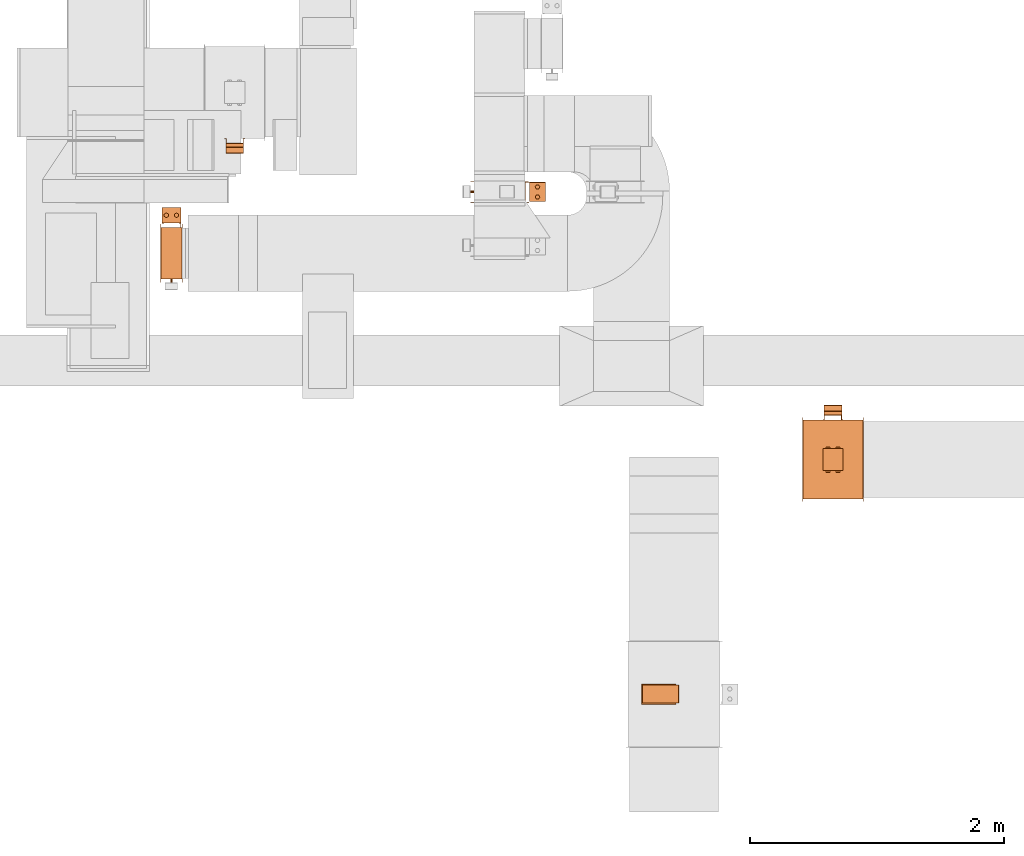
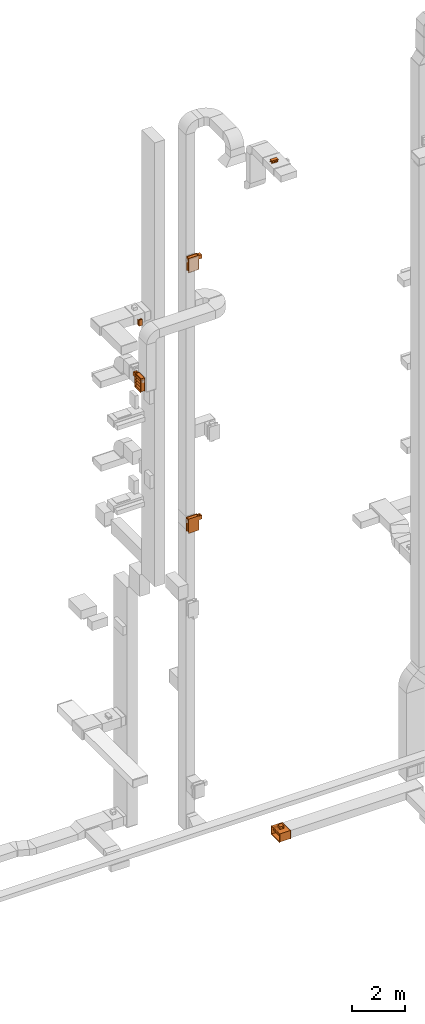
# One storey, part 25 of 29: 7 proxies.
"""IFC2X3 building model written with IfcOpenShell, lengths in millimetres."""

from ifc_helpers import new_model, entity, si_unit, converted_unit, derived_unit, direction, frame, frame_2d, origin, origin_2d_with_axis, place, context, subcontext, project, spatial, polyline, circle_curve, parameter, trimmed, segment, composite_curve, rectangle, circle, hollow_circle, outline, extrude, source, transform, mapped, material, material_list, type_object, type_shapes, element, save


model = new_model("IFC2X3")

# Units and contexts
model_context = context("Model", 3, precision=0.01, world=origin(), true_north=direction((6.12303176911189e-17, 1.0)))
body_context = subcontext(model_context, "Body", "Model", "MODEL_VIEW")
ifc_project = project(units=[si_unit("LENGTHUNIT", "METRE", prefix="MILLI"), si_unit("AREAUNIT", "SQUARE_METRE"), si_unit("VOLUMEUNIT", "CUBIC_METRE"), converted_unit("PLANEANGLEUNIT", "DEGREE", entity("IfcRatioMeasure", 0.0174532925199433), si_unit("PLANEANGLEUNIT", "RADIAN"), dimensions=[0, 0, 0, 0, 0, 0, 0]), si_unit("MASSUNIT", "GRAM", prefix="KILO"), derived_unit("MASSDENSITYUNIT", [(si_unit("MASSUNIT", "GRAM", prefix="KILO"), 1), (si_unit("LENGTHUNIT", "METRE"), -3)]), derived_unit("MOMENTOFINERTIAUNIT", [(si_unit("LENGTHUNIT", "METRE"), 4)]), si_unit("TIMEUNIT", "SECOND"), si_unit("FREQUENCYUNIT", "HERTZ"), si_unit("THERMODYNAMICTEMPERATUREUNIT", "DEGREE_CELSIUS"), derived_unit("THERMALTRANSMITTANCEUNIT", [(si_unit("MASSUNIT", "GRAM", prefix="KILO"), 1), (si_unit("THERMODYNAMICTEMPERATUREUNIT", "KELVIN"), -1), (si_unit("TIMEUNIT", "SECOND"), -3)]), derived_unit("VOLUMETRICFLOWRATEUNIT", [(si_unit("LENGTHUNIT", "METRE"), 3), (si_unit("TIMEUNIT", "SECOND"), -1)]), derived_unit("MASSFLOWRATEUNIT", [(si_unit("MASSUNIT", "GRAM", prefix="KILO"), 1), (si_unit("TIMEUNIT", "SECOND"), -1)]), derived_unit("ROTATIONALFREQUENCYUNIT", [(si_unit("TIMEUNIT", "SECOND"), -1)]), si_unit("ELECTRICCURRENTUNIT", "AMPERE"), si_unit("ELECTRICVOLTAGEUNIT", "VOLT"), si_unit("POWERUNIT", "WATT"), si_unit("FORCEUNIT", "NEWTON", prefix="KILO"), si_unit("ILLUMINANCEUNIT", "LUX"), si_unit("LUMINOUSFLUXUNIT", "LUMEN"), si_unit("LUMINOUSINTENSITYUNIT", "CANDELA"), derived_unit("USERDEFINED", [(si_unit("MASSUNIT", "GRAM", prefix="KILO"), -1), (si_unit("LENGTHUNIT", "METRE"), -2), (si_unit("TIMEUNIT", "SECOND"), 3), (si_unit("LUMINOUSFLUXUNIT", "LUMEN"), 1)]), derived_unit("LINEARVELOCITYUNIT", [(si_unit("LENGTHUNIT", "METRE"), 1), (si_unit("TIMEUNIT", "SECOND"), -1)]), si_unit("PRESSUREUNIT", "PASCAL"), derived_unit("USERDEFINED", [(si_unit("LENGTHUNIT", "METRE"), -2), (si_unit("MASSUNIT", "GRAM", prefix="KILO"), 1), (si_unit("TIMEUNIT", "SECOND"), -2)]), derived_unit("LINEARFORCEUNIT", [(si_unit("MASSUNIT", "GRAM", prefix="KILO"), 1), (si_unit("LENGTHUNIT", "METRE"), 1), (si_unit("TIMEUNIT", "SECOND"), -2), (si_unit("LENGTHUNIT", "METRE"), -1)]), derived_unit("PLANARFORCEUNIT", [(si_unit("MASSUNIT", "GRAM", prefix="KILO"), 1), (si_unit("LENGTHUNIT", "METRE"), 1), (si_unit("TIMEUNIT", "SECOND"), -2), (si_unit("LENGTHUNIT", "METRE"), -2)])], contexts=[model_context])

# Site, building, storey
site_placement = place(None, frame((0.0, -0.00077364408347762, 0.0)))
site = spatial("IfcSite", under=ifc_project, at=site_placement, CompositionType="ELEMENT")
building_placement = place(site_placement, origin())
building = spatial("IfcBuilding", under=site, at=building_placement, CompositionType="ELEMENT")
storey_placement = place(building_placement, origin())
storey = spatial("IfcBuildingStorey", under=building, at=storey_placement, CompositionType="ELEMENT", Elevation=0.0)

# Proxies
ifc_material_1 = material()
ifc_material_2 = material()
ifc_material_list_1 = material_list([ifc_material_1, ifc_material_2])
ifc_material_list_2 = material_list([ifc_material_1, ifc_material_1, ifc_material_2])
building_element_proxy_type_1 = type_object("IfcBuildingElementProxyType", PredefinedType="NOTDEFINED", material=ifc_material_list_2)
shared_shape_1 = source(origin(), body_context, "Body", "SweptSolid", [
    extrude(outline(composite_curve([segment(polyline([(-18.1579434264858, -147.53864987638), (18.0451391047457, -147.53864987638)]), True, "CONTINUOUS"), segment(trimmed(circle_curve(frame_2d((18.0451391047457, -139.094333839161), x_axis=(0.0, -1.0)), 8.44431603721898), [parameter(1.01777749806833e-13)], [parameter(90.0)], True, "PARAMETER"), True, "CONTINUOUS"), segment(polyline([(26.4894551419646, -139.094333839161), (26.4894551419649, 139.30552762976)]), True, "CONTINUOUS"), segment(trimmed(circle_curve(frame_2d((18.3336326481045, 139.30552762976), x_axis=(0.0, -1.0)), 8.15582249386043), [parameter(90.0)], [parameter(180.0)], True, "PARAMETER"), True, "CONTINUOUS"), segment(polyline([(18.3336326481046, 147.46135012362), (-18.1786488941653, 147.461350123621)]), True, "CONTINUOUS"), segment(trimmed(circle_curve(frame_2d((-18.1786488941652, 139.129454159721), x_axis=(0.0, -1.0)), 8.33189596389998), [parameter(180.0)], [parameter(270.0)], True, "PARAMETER"), True, "CONTINUOUS"), segment(polyline([(-26.5105448580647, 139.129454159721), (-26.5105448580641, -139.186048444801)]), True, "CONTINUOUS"), segment(trimmed(circle_curve(frame_2d((-18.1579434264858, -139.186048444801), x_axis=(0.0, -1.0)), 8.35260143157827), [parameter(270.0)], [parameter(4.57999874130747e-13)], True, "PARAMETER"), True, "CONTINUOUS")], self_intersect=False)), frame((-70.0, 12.5386498763715, 91.489455141968), z_axis=(1.0, 0.0, 0.0), x_axis=(0.0, 0.0, -1.0)), (0.0, 0.0, 1.0), 139.999999999992),
    extrude(outline(polyline([(-9.1666666666746, -80.0), (-4.16666666666706, -80.0), (-4.16666666667189, -70.0), (15.8333333333402, -70.0), (15.8333333333402, 70.0), (-4.16666666666706, 70.0), (-4.16666666666706, 80.0), (-9.16666666667441, 80.0), (-9.16666666667492, 65.0), (10.8333333333455, 65.0), (10.8333333333455, -65.0), (-9.16666666667441, -65.0), (-9.1666666666746, -80.0)])), frame((-70.0, 0.0, 49.1666666666727), z_axis=(1.0, 0.0, 0.0), x_axis=(0.0, 0.0, 1.0)), (0.0, 0.0, 1.0), 139.999999999992),
    extrude(outline(polyline([(-14.1666666666698, -80.0), (-9.16666666666213, -80.0), (-9.16666666666697, -70.0), (25.833333333333, -70.0), (25.833333333333, 70.0), (-9.16666666666213, 70.0), (-9.16666666666211, 80.0), (-14.1666666666695, 80.0), (-14.16666666667, 65.0), (20.833333333333, 65.0), (20.833333333333, -65.0), (-14.1666666666695, -65.0), (-14.1666666666698, -80.0)])), frame((0.0, -135.0, 14.1666666666679), z_axis=(0.0, 1.0, 0.0), x_axis=(0.0, 0.0, 1.0)), (0.0, 0.0, 1.0), 270.0),
])
type_shapes(building_element_proxy_type_1, [shared_shape_1])
proxy_1_placement = place(storey_placement, frame((29783.9052184742, 10927.6152449867, 22380.0), z_axis=(0.0, -1.0, 0.0), x_axis=(1.0, 0.0, 0.0)))
element("IfcBuildingElementProxy", 1, at=proxy_1_placement, inside=storey, type_object=building_element_proxy_type_1, material=ifc_material_list_1, context=body_context, shape_type="MappedRepresentation", body=[
    mapped(shared_shape_1, transform((0.0, 0.0, 0.0), scale=1.0)),
])
ifc_material_list_3 = material_list([ifc_material_1, ifc_material_2])
proxy_2_placement = place(storey_placement, frame((33124.0200965316, 6552.95842798016, 31212.0), z_axis=(0.0, 0.0, 1.0), x_axis=(0.0, -1.0, 0.0)))
element("IfcBuildingElementProxy", 2, at=proxy_2_placement, inside=storey, type_object=building_element_proxy_type_1, material=ifc_material_list_3, context=body_context, shape_type="MappedRepresentation", body=[
    mapped(shared_shape_1, transform((0.0, 0.0, 0.0), scale=1.0)),
])
ifc_material_list_4 = material_list([ifc_material_1, ifc_material_2])
proxy_3_placement = place(storey_placement, frame((34495.3986486254, 8712.00003916104, -1370.0), z_axis=(0.0, 1.0, 0.0), x_axis=(-1.0, 0.0, 0.0)))
element("IfcBuildingElementProxy", 3, at=proxy_3_placement, inside=storey, type_object=building_element_proxy_type_1, material=ifc_material_list_4, context=body_context, shape_type="MappedRepresentation", body=[
    mapped(shared_shape_1, transform((0.0, 0.0, 0.0), scale=1.0)),
])
ifc_material_3 = material()
ifc_material_4 = material()
ifc_material_5 = material()
ifc_material_list_5 = material_list([ifc_material_3, ifc_material_4, ifc_material_5, ifc_material_2])
ifc_material_list_6 = material_list([ifc_material_3, ifc_material_3, ifc_material_3, ifc_material_3, ifc_material_3, ifc_material_3, ifc_material_3, ifc_material_3, ifc_material_3, ifc_material_3, ifc_material_3, ifc_material_3, ifc_material_3, ifc_material_3, ifc_material_4, ifc_material_5, ifc_material_2, ifc_material_2, ifc_material_2, ifc_material_2, ifc_material_2, ifc_material_2, ifc_material_2, ifc_material_2, ifc_material_2, ifc_material_2])
building_element_proxy_type_2 = type_object("IfcBuildingElementProxyType", PredefinedType="NOTDEFINED", material=ifc_material_list_6)
shared_shape_2 = source(origin(), body_context, "Body", "SweptSolid", [
    extrude(rectangle(XDim=1.50000000000003, YDim=150.0, at=frame_2d((0.0, 7.105427357601e-15), x_axis=(1.0, 0.0))), frame((0.0, 202.250000000103, 157.249999999651), z_axis=(0.0, 0.0, 1.0), x_axis=(0.0, -1.0, 0.0)), (0.0, 0.0, 1.0), 123.000000000001),
    extrude(outline(polyline([(-11.6740264080913, -10.5031464839717), (-10.1740264080919, -10.5031464839717), (-10.1740264080919, 4.49685351602811), (21.8480528161833, 4.49685351602811), (21.8480528161832, 6.00629296794362), (-11.6740264080913, 6.00629296794362), (-11.6740264080913, -10.5031464839717)])), frame((68.9937070320596, 224.825973592012, 157.249999999651), z_axis=(0.0, 0.0, 1.0), x_axis=(0.0, -1.0, 0.0)), (0.0, 0.0, 1.0), 25.0),
    extrude(outline(polyline([(-10.5031464839719, -11.6740264080911), (6.00629296794368, -11.6740264080911), (6.00629296794368, 21.8480528161829), (4.4968535160282, 21.8480528161829), (4.49685351602819, -10.1740264080918), (-10.5031464839718, -10.1740264080917), (-10.5031464839719, -11.6740264080911)])), frame((-68.9937070320598, 224.825973592013, 157.24999999965), z_axis=(0.0, 0.0, 1.0), x_axis=(-1.0, 0.0, 0.0)), (0.0, 0.0, 1.0), 25.0000000000005),
    extrude(outline(polyline([(-11.6740264080912, -10.503146483972), (-10.1740264080917, -10.503146483972), (-10.174026408092, 4.49685351602798), (21.8480528161832, 4.49685351602851), (21.8480528161831, 6.00629296794398), (-11.6740264080914, 6.00629296794359), (-11.6740264080912, -10.503146483972)])), frame((68.9937070320592, 224.825973592012, 255.249999999653), z_axis=(0.0, 0.0, 1.0), x_axis=(0.0, -1.0, 0.0)), (0.0, 0.0, 1.0), 25.0),
    extrude(outline(polyline([(-9.31403727272934, -16.1323857799607), (9.31403727274035, -16.1323857799607), (18.6280745454669, 0.0), (9.31403727272391, 16.132385779964), (-9.31403727273757, 16.1323857799592), (-18.6280745454642, 0.0), (-9.31403727272934, -16.1323857799607)])), frame((40.0, 299.0, 307.249999999651), z_axis=(0.0, 0.0, 1.0), x_axis=(0.866025403784569, 0.499999999999775, 0.0)), (0.0, 0.0, 1.0), 10.0),
    extrude(outline(polyline([(-9.25778653448417, -16.0349566433469), (9.25778653447845, -16.0349566433469), (18.5155730689596, 0.0), (9.25778653447818, 16.0349566433504), (-9.25778653447542, 16.0349566433453), (-18.5155730689565, 0.0), (-9.25778653448417, -16.0349566433469)])), frame((-40.0, 299.0, 307.249999999651), z_axis=(0.0, 0.0, 1.0), x_axis=(0.866025403784445, 0.499999999999988, 0.0)), (0.0, 0.0, 1.0), 10.0),
    extrude(hollow_circle(Radius=15.0, WallThickness=6.97527274236894, at=frame_2d((1.09711940467341e-28, -6.76791955811495e-14), x_axis=(1.0, 0.0))), frame((-40.0, 299.0, 305.249999999651), z_axis=(0.0, 0.0, 1.0), x_axis=(-1.0, 0.0, 0.0)), (0.0, 0.0, 1.0), 14.0),
    extrude(hollow_circle(Radius=15.0, WallThickness=7.0, at=frame_2d((1.09711940467341e-28, -6.76791955811495e-14), x_axis=(1.0, 0.0))), frame((40.0, 299.0, 305.249999999651), z_axis=(0.0, 0.0, 1.0), x_axis=(-1.0, 0.0, 0.0)), (0.0, 0.0, 1.0), 14.0),
    extrude(outline(polyline([(-10.5031464839719, -11.6740264080911), (6.00629296794375, -11.6740264080911), (6.00629296794375, 21.848052816183), (4.49685351602825, 21.848052816183), (4.49685351602798, -10.1740264080918), (-10.5031464839719, -10.1740264080917), (-10.5031464839719, -11.6740264080911)])), frame((-68.9937070320603, 224.825973592013, 255.249999999653), z_axis=(0.0, 0.0, 1.0), x_axis=(-1.0, 0.0, 0.0)), (0.0, 0.0, 1.0), 25.0),
    extrude(outline(polyline([(-9.31403727272938, -16.1323857799607), (9.31403727274159, -16.1323857799607), (18.6280745454675, 0.0), (9.31403727272273, 16.1323857799646), (-9.31403727273821, 16.1323857799588), (-18.6280745454642, 0.0), (-9.31403727272938, -16.1323857799607)])), frame((40.0, 299.0, 120.249999999651), z_axis=(0.0, 0.0, 1.0), x_axis=(0.866025403784588, 0.499999999999741, 0.0)), (0.0, 0.0, 1.0), 9.99999999999999),
    extrude(outline(polyline([(-9.25778653448427, -16.0349566433469), (9.25778653447836, -16.0349566433469), (18.5155730689595, 0.0), (9.25778653447752, 16.0349566433508), (-9.25778653447492, 16.034956643345), (-18.5155730689561, 0.0), (-9.25778653448427, -16.0349566433469)])), frame((-40.0, 299.0, 120.249999999651), z_axis=(0.0, 0.0, 1.0), x_axis=(0.866025403784446, 0.499999999999988, 0.0)), (0.0, 0.0, 1.0), 9.99999999999999),
    extrude(hollow_circle(Radius=15.0, WallThickness=6.97527274236894, at=frame_2d((1.09711940467341e-28, -6.76791955811495e-14), x_axis=(1.0, 0.0))), frame((-40.0, 299.0, 118.249999999651), z_axis=(0.0, 0.0, 1.0), x_axis=(-1.0, 0.0, 0.0)), (0.0, 0.0, 1.0), 14.0000000000001),
    extrude(hollow_circle(Radius=15.0, WallThickness=7.0, at=frame_2d((1.09711940467341e-28, -6.76791955811495e-14), x_axis=(1.0, 0.0))), frame((40.0, 299.0, 118.249999999651), z_axis=(0.0, 0.0, 1.0), x_axis=(-1.0, 0.0, 0.0)), (0.0, 0.0, 1.0), 14.0000000000001),
    extrude(rectangle(XDim=125.0, YDim=150.0, at=frame_2d((3.19744231092045e-14, 7.105427357601e-15), x_axis=(1.0, 0.0))), frame((0.0, 299.0, 132.24999999965), z_axis=(0.0, 0.0, 1.0), x_axis=(0.0, -1.0, 0.0)), (0.0, 0.0, 1.0), 173.0),
    extrude(outline(polyline([(-91.9238815542516, -374.76659402887), (-49.4974746830587, -374.76659402887), (374.76659402887, 49.4974746830578), (374.76659402887, 91.9238815542507), (91.9238815542516, 374.76659402887), (49.4974746830586, 374.76659402887), (-374.76659402887, -49.4974746830577), (-374.76659402887, -91.9238815542507), (-91.9238815542516, -374.76659402887)]), holes=[polyline([(-70.7106781186565, -353.553390593272), (-353.553390593276, -70.7106781186521), (70.7106781186561, 353.553390593279), (353.553390593276, 70.7106781186588), (-70.7106781186565, -353.553390593272)])]), frame((85.0, 0.0, 0.0), z_axis=(1.0, 0.0, 0.0), x_axis=(0.0, -0.707106781186547, -0.707106781186548)), (0.0, 0.0, 1.0), 1.50000000000001),
    extrude(rectangle(XDim=1.5, YDim=400.0, at=frame_2d((-8.43769498715119e-15, 0.0), x_axis=(1.0, 0.0))), frame((85.7499999999981, 0.0, -300.0)), (0.0, 0.0, 1.0), 600.0),
    extrude(outline(polyline([(-10.7590541572762, -14.9949864557884), (14.2409458427174, -14.9949864557884), (69.8296772996113, -6.991007520203), (69.8296772996113, 6.98098043177924), (14.2409458427207, 15.0050135442119), (-10.7590541572817, 15.005013544212), (-73.3115689850514, 6.98098043177936), (-73.3115689850514, -6.99100752020272), (-10.7590541572762, -14.9949864557884)])), frame((-1.19744613134584, -201.500000000081, 70.9214102133944), z_axis=(0.0, 1.0, 0.0), x_axis=(0.707106781186548, 0.0, 0.707106781186548)), (0.0, 0.0, 1.0), 400.0),
    extrude(outline(polyline([(-10.7590541572762, -14.9949864557884), (14.2409458427174, -14.9949864557884), (69.8296772996113, -6.991007520203), (69.8296772996113, 6.98098043177924), (14.2409458427207, 15.0050135442119), (-10.7590541572817, 15.005013544212), (-73.3115689850514, 6.98098043177937), (-73.3115689850514, -6.99100752020272), (-10.7590541572762, -14.9949864557884)])), frame((-1.19744613134584, -201.50000000008, -73.9119231199388), z_axis=(0.0, 1.0, 0.0), x_axis=(0.707106781186548, 0.0, 0.707106781186548)), (0.0, 0.0, 1.0), 400.0),
    extrude(outline(polyline([(-10.7590541572762, -14.9949864557884), (14.2409458427174, -14.9949864557884), (69.8296772996113, -6.99100752020298), (69.8296772996113, 6.98098043177923), (14.2409458427207, 15.0050135442119), (-10.7590541572817, 15.005013544212), (-73.3115689850514, 6.98098043177935), (-73.3115689850514, -6.99100752020274), (-10.7590541572762, -14.9949864557884)])), frame((-1.19744613134584, -201.50000000008, 215.754743546728), z_axis=(0.0, 1.0, 0.0), x_axis=(0.707106781186548, 0.0, 0.707106781186548)), (0.0, 0.0, 1.0), 400.0),
    extrude(outline(polyline([(-10.7590541572762, -14.9949864557884), (14.2409458427174, -14.9949864557884), (69.8296772996113, -6.99100752020298), (69.8296772996113, 6.98098043177923), (14.2409458427207, 15.0050135442119), (-10.7590541572817, 15.005013544212), (-73.3115689850514, 6.98098043177935), (-73.3115689850514, -6.99100752020274), (-10.7590541572762, -14.9949864557884)])), frame((-1.19744613134584, -201.500000000081, -218.745256453272), z_axis=(0.0, 1.0, 0.0), x_axis=(0.707106781186548, 0.0, 0.707106781186548)), (0.0, 0.0, 1.0), 400.0),
    extrude(outline(polyline([(-201.500000000085, -301.500000000003), (201.500000000085, -301.500000000003), (201.500000000085, 301.500000000003), (-201.500000000085, 301.500000000003), (-201.500000000085, -301.500000000003)]), holes=[polyline([(200.0, -300.0), (-200.0, -300.0), (-200.0, 300.0), (200.0, 300.0), (200.0, -300.0)])]), frame((-83.5000000000015, 0.0, 0.0), z_axis=(1.0, 0.0, 0.0), x_axis=(0.0, -1.0, 0.0)), (0.0, 0.0, 1.0), 167.0),
    extrude(rectangle(XDim=1.5, YDim=400.000000000054, at=origin_2d_with_axis()), frame((-0.75, 0.0, 291.0), z_axis=(0.0, 0.0, 1.0), x_axis=(-1.0, 0.0, 0.0)), (0.0, 0.0, 1.0), 8.99999999964964),
    extrude(rectangle(XDim=1.5, YDim=399.999999999998, at=origin_2d_with_axis()), frame((-0.75, 0.0, -300.0), z_axis=(0.0, 0.0, 1.0), x_axis=(-1.0, 0.0, 0.0)), (0.0, 0.0, 1.0), 9.00000000035571),
    extrude(outline(polyline([(-330.0, -229.983568238304), (-301.500000000001, -229.983568238304), (301.499999999999, -229.983568238304), (330.0, -229.983568238304), (330.0, 229.983568238304), (301.499999999999, 229.983568238304), (-301.500000000001, 229.983568238304), (-330.0, 229.983568238304), (-330.0, -229.983568238304)]), holes=[polyline([(-300.0, 200.016431761674), (300.0, 200.016431761674), (300.0, -199.983568238324), (-300.0, -199.983568238324), (-300.0, 200.016431761674)])]), frame((83.4999999999988, -0.0164317617789846, 0.0), z_axis=(1.0, 0.0, 0.0), x_axis=(0.0, 0.0, -1.0)), (0.0, 0.0, 1.0), 1.49999999999925),
    extrude(outline(polyline([(-330.0, -229.983568238491), (-301.5, -229.983568238491), (301.5, -229.983568238491), (330.0, -229.983568238491), (330.0, 229.983568238491), (301.5, 229.983568238491), (-301.5, 229.983568238492), (-330.0, 229.983568238491), (-330.0, -229.983568238491)]), holes=[polyline([(-300.0, 200.016431761505), (300.0, 200.016431761505), (300.0, -199.983568238493), (-300.0, -199.983568238493), (-300.0, 200.016431761505)])]), frame((-85.0, -0.0164317615959716, 0.0), z_axis=(1.0, 0.0, 0.0), x_axis=(0.0, 0.0, -1.0)), (0.0, 0.0, 1.0), 1.50000000000074),
    extrude(circle(Radius=8.0, at=frame_2d((0.0, -1.29243565954607e-14), x_axis=(1.0, 0.0))), frame((0.0, -230.0, 218.750000000002), z_axis=(0.0, 1.0, 0.0), x_axis=(0.0, 0.0, 1.0)), (0.0, 0.0, 1.0), 28.5),
])
type_shapes(building_element_proxy_type_2, [shared_shape_2])
proxy_4_placement = place(storey_placement, frame((31869.8913763301, 10507.4235279463, 24600.0), z_axis=(0.0, 0.0, 1.0), x_axis=(0.0, -1.0, 0.0)))
element("IfcBuildingElementProxy", 4, at=proxy_4_placement, inside=storey, type_object=building_element_proxy_type_2, material=ifc_material_list_5, context=body_context, shape_type="MappedRepresentation", body=[
    mapped(shared_shape_2, transform((0.0, 0.0, 0.0), scale=1.0)),
])
ifc_material_list_7 = material_list([ifc_material_3, ifc_material_4, ifc_material_5, ifc_material_2])
proxy_5_placement = place(storey_placement, frame((29285.5638771014, 10024.9425362384, 20300.0)))
element("IfcBuildingElementProxy", 5, at=proxy_5_placement, inside=storey, type_object=building_element_proxy_type_2, material=ifc_material_list_7, context=body_context, shape_type="MappedRepresentation", body=[
    mapped(shared_shape_2, transform((0.0, 0.0, 0.0), scale=1.0)),
])
ifc_material_list_8 = material_list([ifc_material_3, ifc_material_4, ifc_material_5, ifc_material_2])
proxy_6_placement = place(storey_placement, frame((31869.8913763301, 10509.9993759155, 12600.0), z_axis=(0.0, 0.0, 1.0), x_axis=(0.0, -1.0, 0.0)))
element("IfcBuildingElementProxy", 6, at=proxy_6_placement, inside=storey, type_object=building_element_proxy_type_2, material=ifc_material_list_8, context=body_context, shape_type="MappedRepresentation", body=[
    mapped(shared_shape_2, transform((0.0, 0.0, 0.0), scale=1.0)),
])
ifc_material_list_9 = material_list([ifc_material_3, ifc_material_3, ifc_material_3, ifc_material_3, ifc_material_3, ifc_material_3, ifc_material_3, ifc_material_3, ifc_material_3, ifc_material_3, ifc_material_3, ifc_material_3, ifc_material_3, ifc_material_3, ifc_material_2, ifc_material_2, ifc_material_2, ifc_material_2, ifc_material_2])
ifc_material_list_10 = material_list([ifc_material_3, ifc_material_3, ifc_material_3, ifc_material_3, ifc_material_3, ifc_material_3, ifc_material_3, ifc_material_3, ifc_material_3, ifc_material_3, ifc_material_3, ifc_material_3, ifc_material_3, ifc_material_3, ifc_material_2, ifc_material_2, ifc_material_2, ifc_material_2, ifc_material_2])
building_element_proxy_type_3 = type_object("IfcBuildingElementProxyType", PredefinedType="NOTDEFINED", material=ifc_material_list_10)
shared_shape_3 = source(origin(), body_context, "Body", "SweptSolid", [
    extrude(rectangle(XDim=1.5, YDim=170.0, at=origin_2d_with_axis()), frame((0.0, -187.750000000076, -62.0), z_axis=(0.0, 0.0, 1.0), x_axis=(0.0, 1.0, 0.0)), (0.0, 0.0, 1.0), 123.000000000001),
    extrude(outline(polyline([(-5.0073597414186, -14.1635201826924), (-3.50735974141924, -14.1635201826924), (-3.50735974141928, 6.32704036539947), (8.51471948283784, 6.3270403654089), (8.51471948283784, 7.83647981728816), (-5.0073597414186, 7.83647981728816), (-5.0073597414186, -14.1635201826924)])), frame((-72.1635201826895, -196.99264025864, -62.0), z_axis=(0.0, 0.0, 1.0), x_axis=(0.0, 1.0, 0.0)), (0.0, 0.0, 1.0), 25.0),
    extrude(outline(polyline([(-13.8364798173165, -5.00735974141877), (7.67295963462824, -5.00735974141877), (7.67295963462824, 8.51471948283771), (6.16352018269341, 8.51471948283771), (6.16352018268311, -3.50735974141894), (-13.8364798173165, -3.50735974141894), (-13.8364798173165, -5.00735974141877)])), frame((72.3270403653872, -196.99264025864, -62.0)), (0.0, 0.0, 1.0), 25.0000000000005),
    extrude(outline(polyline([(-5.0073597414185, -14.163520182702), (-3.50735974141951, -14.163520182702), (-3.50735974141951, 6.3270403653898), (8.51471948283794, 6.32704036538944), (8.51471948283794, 7.83647981731237), (-5.0073597414185, 7.83647981731237), (-5.0073597414185, -14.163520182702)])), frame((-72.1635201826969, -196.99264025864, 36.0), z_axis=(0.0, 0.0, 1.0), x_axis=(0.0, 1.0, 0.0)), (0.0, 0.0, 1.0), 25.0),
    extrude(outline(polyline([(-9.39005042212512, -16.0890911238458), (8.81483867126942, -16.0890911238458), (18.3453872917851, -0.0836606621788718), (9.67104681890712, 15.9217697994894), (-8.95533686966041, 16.172751786024), (-18.4858854901761, 0.167321324356962), (-9.39005042212512, -16.0890911238458)])), frame((-39.8364798173101, -264.500000000062, 88.0), z_axis=(0.0, 0.0, 1.0), x_axis=(-0.859210135894937, -0.511622851693906, 0.0)), (0.0, 0.0, 1.0), 9.99999999999999),
    extrude(outline(polyline([(-9.25778653449055, -16.0349566433433), (9.25778653447246, -16.0349566433433), (18.5155730689534, 0.0), (9.25778653447181, 16.0349566433542), (-9.25778653446301, 16.0349566433379), (-18.515573068944, 0.0), (-9.25778653449055, -16.0349566433433)])), frame((40.0, -264.500000000057, 88.0), z_axis=(0.0, 0.0, 1.0), x_axis=(-0.86602540378445, -0.499999999999979, 0.0)), (0.0, 0.0, 1.0), 10.0),
    extrude(hollow_circle(Radius=15.0, WallThickness=6.97527274236894, at=frame_2d((3.55257043274876e-28, -6.76791955811494e-14), x_axis=(1.0, 0.0))), frame((40.0, -264.500000000057, 86.0)), (0.0, 0.0, 1.0), 14.0),
    extrude(hollow_circle(Radius=15.0, WallThickness=7.0, at=frame_2d((1.00544105397778e-41, -6.76791955811495e-14), x_axis=(1.0, 0.0))), frame((-40.0, -264.500000000057, 86.0)), (0.0, 0.0, 1.0), 14.0),
    extrude(outline(polyline([(-13.8364798173041, -5.0073597414186), (7.67295963460837, -5.0073597414186), (7.67295963460837, 8.51471948283787), (6.16352018269594, 8.51471948283787), (6.1635201826955, -3.50735974141934), (-13.8364798173041, -3.50735974141934), (-13.8364798173041, -5.0073597414186)])), frame((72.3270403653869, -196.99264025864, 36.0)), (0.0, 0.0, 1.0), 25.0),
    extrude(outline(polyline([(-9.39005042212341, -16.0890911238458), (8.81483867127266, -16.0890911238458), (18.3453872917859, -0.0836606621775066), (9.67104681890322, 15.9217697994909), (-8.95533686966253, 16.1727517860234), (-18.4858854901759, 0.167321324354935), (-9.39005042212341, -16.0890911238458)])), frame((-39.8364798173151, -264.500000000064, -98.0), z_axis=(0.0, 0.0, 1.0), x_axis=(-0.859210135895012, -0.511622851693779, 0.0)), (0.0, 0.0, 1.0), 9.99999999999999),
    extrude(outline(polyline([(-9.25778653449123, -16.0349566433429), (9.2577865344714, -16.0349566433429), (18.5155730689525, 0.0), (9.25778653447022, 16.034956643355), (-9.25778653446088, 16.0349566433369), (-18.5155730689421, 0.0), (-9.25778653449123, -16.0349566433429)])), frame((40.0, -264.500000000059, -98.0), z_axis=(0.0, 0.0, 1.0), x_axis=(-0.866025403784445, -0.49999999999999, 0.0)), (0.0, 0.0, 1.0), 9.99999999999999),
    extrude(hollow_circle(Radius=15.0, WallThickness=6.97527274236894, at=frame_2d((1.00544105397778e-41, -6.76791955811495e-14), x_axis=(1.0, 0.0))), frame((40.0, -264.500000000059, -100.0)), (0.0, 0.0, 1.0), 14.0000000000002),
    extrude(hollow_circle(Radius=15.0, WallThickness=7.0, at=frame_2d((1.00544105397778e-41, -6.76791955811495e-14), x_axis=(1.0, 0.0))), frame((-40.0, -264.500000000059, -100.0)), (0.0, 0.0, 1.0), 14.0000000000002),
    extrude(rectangle(XDim=127.0, YDim=159.999999999992, at=frame_2d((3.5527136788005e-14, 1.4210854715202e-14), x_axis=(1.0, 0.0))), frame((0.0, -265.500000000059, -86.0), z_axis=(0.0, 0.0, 1.0), x_axis=(0.0, 1.0, 0.0)), (0.0, 0.0, 1.0), 171.999999999999),
    extrude(outline(polyline([(-187.0, -312.0), (187.0, -312.0), (187.0, 312.0), (-187.0, 312.0), (-187.0, -312.0)]), holes=[polyline([(175.0, 300.0), (175.0, -300.0), (-175.0, -300.0), (-175.0, 300.0), (175.0, 300.0)])]), frame((-240.0, 0.0, 0.0), z_axis=(1.0, 0.0, 0.0), x_axis=(0.0, -1.0, 0.0)), (0.0, 0.0, 1.0), 480.0),
    extrude(rectangle(XDim=346.0, YDim=24.0000000000003, at=origin_2d_with_axis()), frame((0.0, 0.0, -288.0), z_axis=(0.0, 0.0, 1.0), x_axis=(-1.0, 0.0, 0.0)), (0.0, 0.0, 1.0), 576.000000000017),
    extrude(outline(polyline([(-205.0, -330.0), (205.0, -330.0), (205.0, 330.0), (-205.0, 330.0), (-205.0, -330.0)]), holes=[polyline([(-175.0, -300.0), (-175.0, 300.0), (175.0, 300.0), (175.0, -300.0), (-175.0, -300.0)])]), frame((235.0, 0.0, 0.0), z_axis=(1.0, 0.0, 0.0), x_axis=(0.0, -1.0, 0.0)), (0.0, 0.0, 1.0), 5.00000000000319),
    extrude(outline(polyline([(-205.0, -330.0), (205.0, -330.0), (205.0, 330.0), (-205.0, 330.0), (-205.0, -330.0)]), holes=[polyline([(-175.0, -300.0), (-175.0, 300.0), (175.0, 300.0), (175.0, -300.0), (-175.0, -300.0)])]), frame((-240.0, 0.0, 0.0), z_axis=(1.0, 0.0, 0.0), x_axis=(0.0, -1.0, 0.0)), (0.0, 0.0, 1.0), 4.99999999999991),
    extrude(outline(polyline([(-300.0, -175.0), (300.0, -175.0), (300.0, 175.0), (-300.0, 175.0), (-300.0, -175.0)]), holes=[polyline([(288.0, -163.0), (-288.0, -163.0), (-288.0, 163.0), (288.0, 163.0), (288.0, -163.0)])]), frame((-6.0, 0.0, 0.0), z_axis=(1.0, 0.0, 0.0), x_axis=(0.0, 0.0, -1.0)), (0.0, 0.0, 1.0), 12.0),
])
type_shapes(building_element_proxy_type_3, [shared_shape_3])
proxy_7_placement = place(storey_placement, frame((34495.3986486254, 8400.00003916102, -1250.0), z_axis=(0.0, 1.0, 0.0), x_axis=(1.0, 0.0, 0.0)))
element("IfcBuildingElementProxy", 7, at=proxy_7_placement, inside=storey, type_object=building_element_proxy_type_3, material=ifc_material_list_9, context=body_context, shape_type="MappedRepresentation", body=[
    mapped(shared_shape_3, transform((0.0, 0.0, 0.0), scale=1.0)),
])

save(model, "model.ifc")
